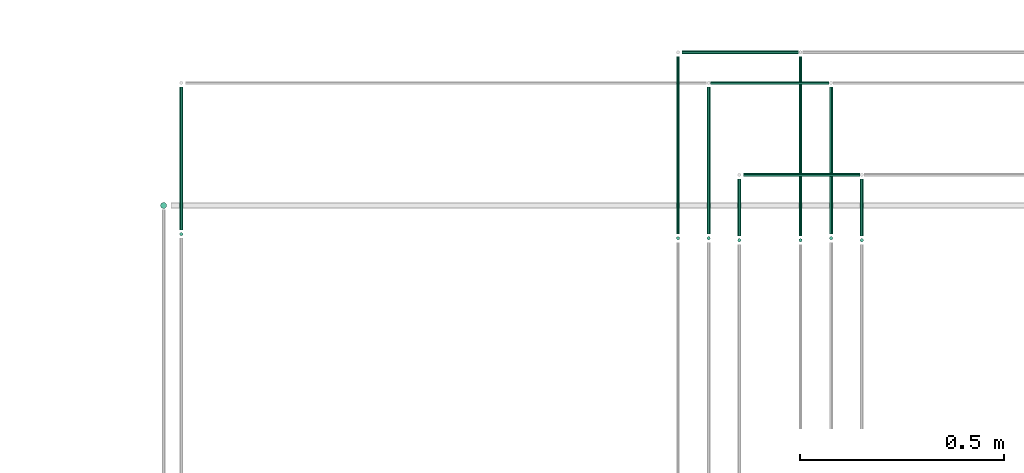
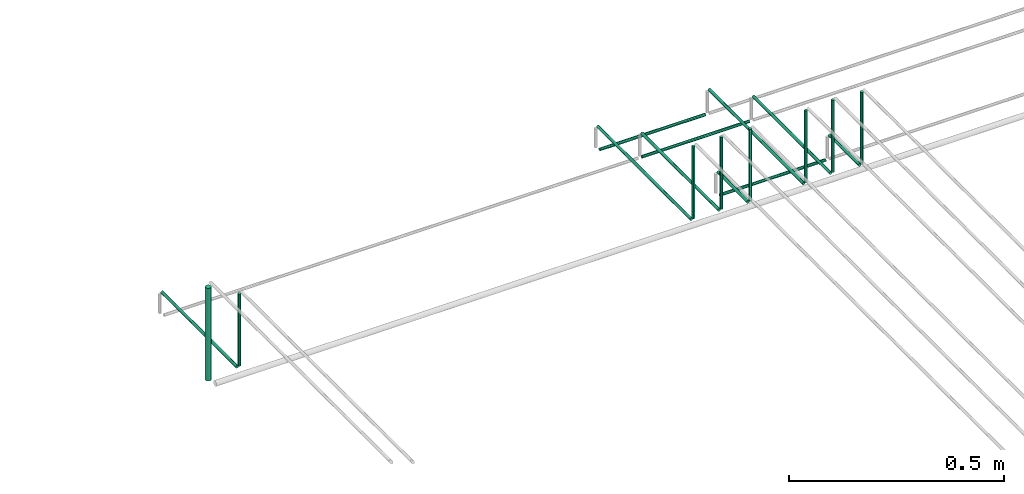
# One storey, part 43 of 89: 18 flow segments.
"""IFC2X3 building model written with IfcOpenShell, lengths in millimetres."""

from ifc_helpers import new_model, entity, si_unit, converted_unit, derived_unit, direction, frame, origin, origin_2d_with_axis, place, context, subcontext, project, spatial, circle, extrude, type_object, element, save


model = new_model("IFC2X3")

# Units and contexts
model_context = context("Model", 3, precision=0.01, world=origin(), true_north=direction((6.12303176911189e-17, 1.0)))
body_context = subcontext(model_context, "Body", "Model", "MODEL_VIEW")
ifc_project = project(units=[si_unit("LENGTHUNIT", "METRE", prefix="MILLI"), si_unit("AREAUNIT", "SQUARE_METRE"), si_unit("VOLUMEUNIT", "CUBIC_METRE"), converted_unit("PLANEANGLEUNIT", "DEGREE", entity("IfcRatioMeasure", 0.0174532925199433), si_unit("PLANEANGLEUNIT", "RADIAN"), dimensions=[0, 0, 0, 0, 0, 0, 0]), si_unit("MASSUNIT", "GRAM", prefix="KILO"), derived_unit("MASSDENSITYUNIT", [(si_unit("MASSUNIT", "GRAM", prefix="KILO"), 1), (si_unit("LENGTHUNIT", "METRE"), -3)]), derived_unit("MOMENTOFINERTIAUNIT", [(si_unit("LENGTHUNIT", "METRE"), 4)]), si_unit("TIMEUNIT", "SECOND"), si_unit("FREQUENCYUNIT", "HERTZ"), si_unit("THERMODYNAMICTEMPERATUREUNIT", "DEGREE_CELSIUS"), derived_unit("THERMALTRANSMITTANCEUNIT", [(si_unit("MASSUNIT", "GRAM", prefix="KILO"), 1), (si_unit("THERMODYNAMICTEMPERATUREUNIT", "KELVIN"), -1), (si_unit("TIMEUNIT", "SECOND"), -3)]), derived_unit("VOLUMETRICFLOWRATEUNIT", [(si_unit("LENGTHUNIT", "METRE"), 3), (si_unit("TIMEUNIT", "SECOND"), -1)]), derived_unit("MASSFLOWRATEUNIT", [(si_unit("MASSUNIT", "GRAM", prefix="KILO"), 1), (si_unit("TIMEUNIT", "SECOND"), -1)]), derived_unit("ROTATIONALFREQUENCYUNIT", [(si_unit("TIMEUNIT", "SECOND"), -1)]), si_unit("ELECTRICCURRENTUNIT", "AMPERE"), si_unit("ELECTRICVOLTAGEUNIT", "VOLT"), si_unit("POWERUNIT", "WATT"), si_unit("FORCEUNIT", "NEWTON", prefix="KILO"), si_unit("ILLUMINANCEUNIT", "LUX"), si_unit("LUMINOUSFLUXUNIT", "LUMEN"), si_unit("LUMINOUSINTENSITYUNIT", "CANDELA"), derived_unit("USERDEFINED", [(si_unit("MASSUNIT", "GRAM", prefix="KILO"), -1), (si_unit("LENGTHUNIT", "METRE"), -2), (si_unit("TIMEUNIT", "SECOND"), 3), (si_unit("LUMINOUSFLUXUNIT", "LUMEN"), 1)]), derived_unit("LINEARVELOCITYUNIT", [(si_unit("LENGTHUNIT", "METRE"), 1), (si_unit("TIMEUNIT", "SECOND"), -1)]), si_unit("PRESSUREUNIT", "PASCAL"), derived_unit("USERDEFINED", [(si_unit("LENGTHUNIT", "METRE"), -2), (si_unit("MASSUNIT", "GRAM", prefix="KILO"), 1), (si_unit("TIMEUNIT", "SECOND"), -2)]), derived_unit("LINEARFORCEUNIT", [(si_unit("MASSUNIT", "GRAM", prefix="KILO"), 1), (si_unit("LENGTHUNIT", "METRE"), 1), (si_unit("TIMEUNIT", "SECOND"), -2), (si_unit("LENGTHUNIT", "METRE"), -1)]), derived_unit("PLANARFORCEUNIT", [(si_unit("MASSUNIT", "GRAM", prefix="KILO"), 1), (si_unit("LENGTHUNIT", "METRE"), 1), (si_unit("TIMEUNIT", "SECOND"), -2), (si_unit("LENGTHUNIT", "METRE"), -2)])], contexts=[model_context])

# Site, building, storey
site_placement = place(None, frame((0.0, -0.00077364408347762, 0.0)))
site = spatial("IfcSite", under=ifc_project, at=site_placement, CompositionType="ELEMENT")
building_placement = place(site_placement, origin())
building = spatial("IfcBuilding", under=site, at=building_placement, CompositionType="ELEMENT")
storey_placement = place(building_placement, frame((0.0, 0.0, 24000.0)))
storey = spatial("IfcBuildingStorey", under=building, at=storey_placement, CompositionType="ELEMENT", Elevation=24000.0)

# Flow segments
pipe_segment_type = type_object("IfcPipeSegmentType", PredefinedType="NOTDEFINED")
flow_segment_1_placement = place(storey_placement, frame((41767.8043091156, 18640.9047277641, 2793.0)))
element("IfcFlowSegment", 1, at=flow_segment_1_placement, inside=storey, type_object=pipe_segment_type, context=body_context, shape_type="SweptSolid", body=[
    extrude(circle(Radius=7.5, at=origin_2d_with_axis()), frame((9.09527223591419, 9.09527223591636, 0.0)), (0.0, 0.0, 1.0), 264.000000000001),
])
flow_segment_2_placement = place(storey_placement, frame((41814.4237854135, 18590.0, 2844.40472776408)))
element("IfcFlowSegment", 2, at=flow_segment_2_placement, inside=storey, type_object=pipe_segment_type, context=body_context, shape_type="SweptSolid", body=[
    extrude(circle(Radius=4.0, at=origin_2d_with_axis()), frame((5.59527223591499, 0.0, 5.59527223591499), z_axis=(0.0, 1.0, 0.0), x_axis=(1.0, 0.0, 0.0)), (0.0, 0.0, 1.0), 350.000007308975),
])
flow_segment_3_placement = place(storey_placement, frame((41814.4237854135, 18574.4047204552, 2860.0)))
element("IfcFlowSegment", 3, at=flow_segment_3_placement, inside=storey, type_object=pipe_segment_type, context=body_context, shape_type="SweptSolid", body=[
    extrude(circle(Radius=4.0, at=origin_2d_with_axis()), frame((5.59527223591499, 5.59527223591499, 0.0)), (0.0, 0.0, 1.0), 205.000000000027),
])
flow_segment_4_placement = place(storey_placement, frame((43030.0262171238, 18580.0, 2844.4047277641)))
element("IfcFlowSegment", 4, at=flow_segment_4_placement, inside=storey, type_object=pipe_segment_type, context=body_context, shape_type="SweptSolid", body=[
    extrude(circle(Radius=4.0, at=origin_2d_with_axis()), frame((5.59527223591499, 0.0, 5.59527223591499), z_axis=(0.0, 1.0, 0.0), x_axis=(-1.0, 0.0, 0.0)), (0.0, 0.0, 1.0), 435.000007308949),
])
flow_segment_5_placement = place(storey_placement, frame((43030.0262171238, 18564.4047204552, 2860.0)))
element("IfcFlowSegment", 5, at=flow_segment_5_placement, inside=storey, type_object=pipe_segment_type, context=body_context, shape_type="SweptSolid", body=[
    extrude(circle(Radius=4.0, at=origin_2d_with_axis()), frame((5.59527223591499, 5.59527223591499, 0.0)), (0.0, 0.0, 1.0), 205.000000000023),
])
flow_segment_6_placement = place(storey_placement, frame((43105.0262171238, 18580.0, 2844.4047277641)))
element("IfcFlowSegment", 6, at=flow_segment_6_placement, inside=storey, type_object=pipe_segment_type, context=body_context, shape_type="SweptSolid", body=[
    extrude(circle(Radius=4.0, at=origin_2d_with_axis()), frame((5.59527223591499, 0.0, 5.59527223591499), z_axis=(0.0, 1.0, 0.0), x_axis=(-1.0, 0.0, 0.0)), (0.0, 0.0, 1.0), 360.000007308938),
])
flow_segment_7_placement = place(storey_placement, frame((43105.0262171238, 18564.4047204552, 2860.0)))
element("IfcFlowSegment", 7, at=flow_segment_7_placement, inside=storey, type_object=pipe_segment_type, context=body_context, shape_type="SweptSolid", body=[
    extrude(circle(Radius=4.0, at=origin_2d_with_axis()), frame((5.59527223591499, 5.59527223591499, 0.0)), (0.0, 0.0, 1.0), 205.000000000018),
])
flow_segment_8_placement = place(storey_placement, frame((43404.7408194806, 18580.0, 2844.4047277641)))
element("IfcFlowSegment", 8, at=flow_segment_8_placement, inside=storey, type_object=pipe_segment_type, context=body_context, shape_type="SweptSolid", body=[
    extrude(circle(Radius=4.0, at=origin_2d_with_axis()), frame((5.59527223591499, 0.0, 5.59527223591499), z_axis=(0.0, 1.0, 0.0), x_axis=(-1.0, 0.0, 0.0)), (0.0, 0.0, 1.0), 360.00000730894),
])
flow_segment_9_placement = place(storey_placement, frame((43404.7408194806, 18564.4047204552, 2860.0)))
element("IfcFlowSegment", 9, at=flow_segment_9_placement, inside=storey, type_object=pipe_segment_type, context=body_context, shape_type="SweptSolid", body=[
    extrude(circle(Radius=4.0, at=origin_2d_with_axis()), frame((5.59527223591499, 5.59527223591499, 0.0)), (0.0, 0.0, 1.0), 205.000000000018),
])
flow_segment_10_placement = place(storey_placement, frame((43180.0262171238, 18575.0, 2844.4047277641)))
element("IfcFlowSegment", 10, at=flow_segment_10_placement, inside=storey, type_object=pipe_segment_type, context=body_context, shape_type="SweptSolid", body=[
    extrude(circle(Radius=4.0, at=origin_2d_with_axis()), frame((5.59527223591499, 0.0, 5.59527223591499), z_axis=(0.0, 1.0, 0.0), x_axis=(-1.0, 0.0, 0.0)), (0.0, 0.0, 1.0), 140.000007308938),
])
flow_segment_11_placement = place(storey_placement, frame((43180.0262171238, 18559.4047204552, 2860.0)))
element("IfcFlowSegment", 11, at=flow_segment_11_placement, inside=storey, type_object=pipe_segment_type, context=body_context, shape_type="SweptSolid", body=[
    extrude(circle(Radius=4.0, at=origin_2d_with_axis()), frame((5.59527223591499, 5.59527223591499, 0.0)), (0.0, 0.0, 1.0), 205.000000000023),
])
flow_segment_12_placement = place(storey_placement, frame((43329.7408194806, 18575.0, 2844.4047277641)))
element("IfcFlowSegment", 12, at=flow_segment_12_placement, inside=storey, type_object=pipe_segment_type, context=body_context, shape_type="SweptSolid", body=[
    extrude(circle(Radius=4.0, at=origin_2d_with_axis()), frame((5.59527223591499, 0.0, 5.59527223591499), z_axis=(0.0, 1.0, 0.0), x_axis=(-1.0, 0.0, 0.0)), (0.0, 0.0, 1.0), 440.000007308952),
])
flow_segment_13_placement = place(storey_placement, frame((43329.7408194806, 18559.4047204552, 2860.0)))
element("IfcFlowSegment", 13, at=flow_segment_13_placement, inside=storey, type_object=pipe_segment_type, context=body_context, shape_type="SweptSolid", body=[
    extrude(circle(Radius=4.0, at=origin_2d_with_axis()), frame((5.59527223591499, 5.59527223591499, 0.0)), (0.0, 0.0, 1.0), 205.000000000018),
])
flow_segment_14_placement = place(storey_placement, frame((43479.7408194806, 18575.0, 2844.4047277641)))
element("IfcFlowSegment", 14, at=flow_segment_14_placement, inside=storey, type_object=pipe_segment_type, context=body_context, shape_type="SweptSolid", body=[
    extrude(circle(Radius=4.0, at=origin_2d_with_axis()), frame((5.59527223591499, 0.0, 5.59527223591499), z_axis=(0.0, 1.0, 0.0), x_axis=(-1.0, 0.0, 0.0)), (0.0, 0.0, 1.0), 140.000007308938),
])
flow_segment_15_placement = place(storey_placement, frame((43479.7408194806, 18559.4047204552, 2860.0)))
element("IfcFlowSegment", 15, at=flow_segment_15_placement, inside=storey, type_object=pipe_segment_type, context=body_context, shape_type="SweptSolid", body=[
    extrude(circle(Radius=4.0, at=origin_2d_with_axis()), frame((5.59527223591499, 5.59527223591499, 0.0)), (0.0, 0.0, 1.0), 205.000000000018),
])
flow_segment_16_placement = place(storey_placement, frame((43195.6214893597, 18719.4047277642, 2769.40472776407)))
element("IfcFlowSegment", 16, at=flow_segment_16_placement, inside=storey, type_object=pipe_segment_type, context=body_context, shape_type="SweptSolid", body=[
    extrude(circle(Radius=4.0, at=origin_2d_with_axis()), frame((0.0, 5.59527223591282, 5.59527223591499), z_axis=(1.0, 0.0, 0.0), x_axis=(0.0, -1.0, 0.0)), (0.0, 0.0, 1.0), 284.714602356819),
])
flow_segment_17_placement = place(storey_placement, frame((43115.6214893597, 18944.4047277642, 2769.40472776409)))
element("IfcFlowSegment", 17, at=flow_segment_17_placement, inside=storey, type_object=pipe_segment_type, context=body_context, shape_type="SweptSolid", body=[
    extrude(circle(Radius=4.0, at=origin_2d_with_axis()), frame((0.0, 5.59527223591282, 5.59527223591499), z_axis=(1.0, 0.0, 0.0), x_axis=(0.0, -1.0, 0.0)), (0.0, 0.0, 1.0), 289.714602356818),
])
flow_segment_18_placement = place(storey_placement, frame((43045.6214893597, 19019.4047277642, 2769.40472776407)))
element("IfcFlowSegment", 18, at=flow_segment_18_placement, inside=storey, type_object=pipe_segment_type, context=body_context, shape_type="SweptSolid", body=[
    extrude(circle(Radius=4.0, at=origin_2d_with_axis()), frame((0.0, 5.59527223591282, 5.59527223591499), z_axis=(1.0, 0.0, 0.0), x_axis=(0.0, -1.0, 0.0)), (0.0, 0.0, 1.0), 284.714602356836),
])

save(model, "model.ifc")
